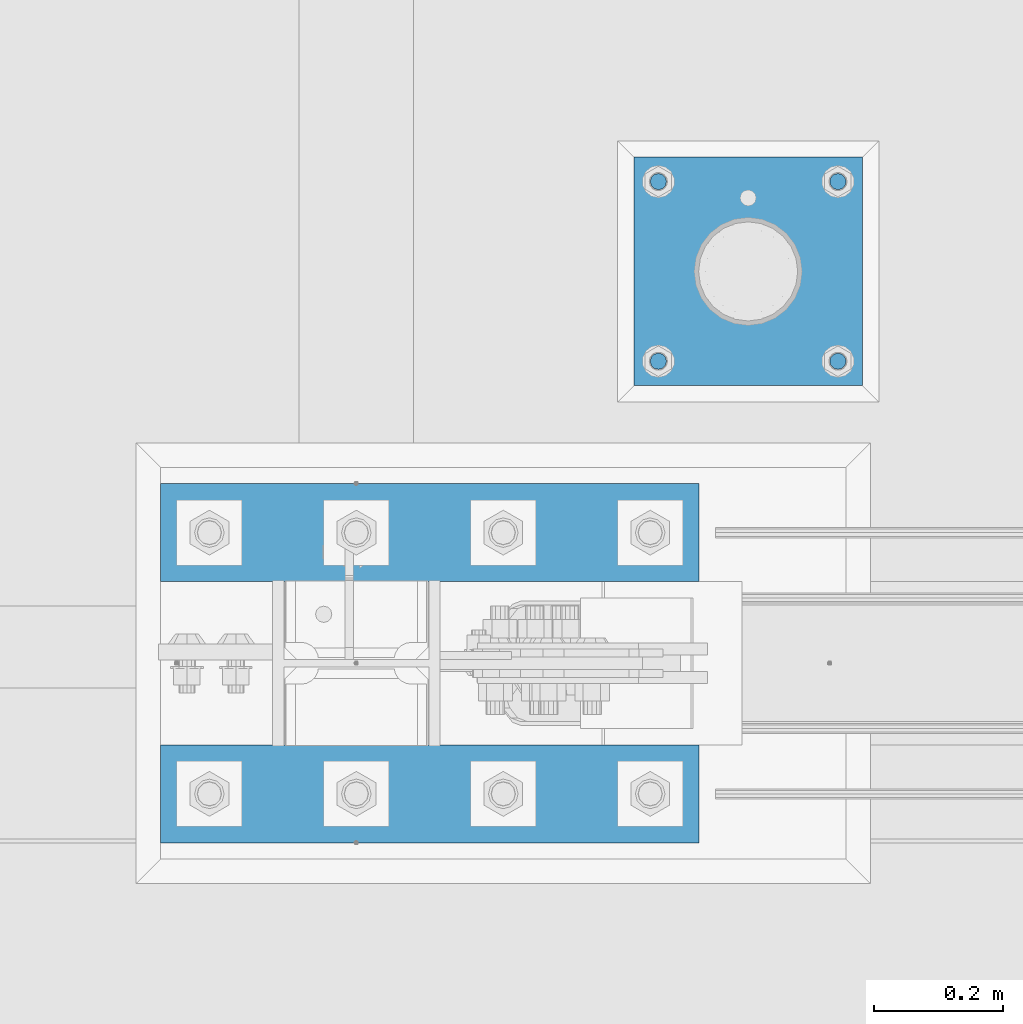
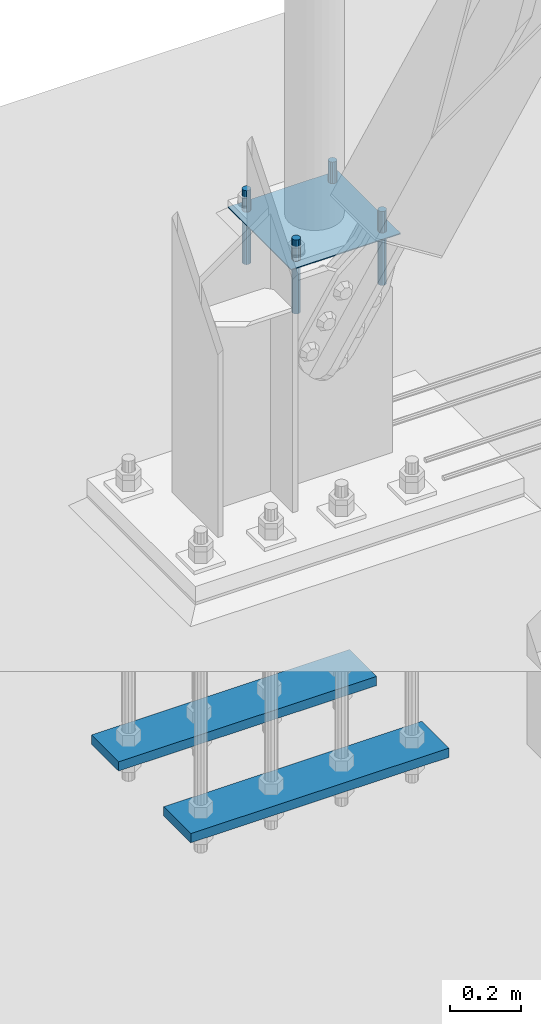
# One storey, part 2399 of 3843: 7 beams, 2 elements without a shape of their own.
"""IFC2X3 building model written with IfcOpenShell, lengths in millimetres."""

from ifc_helpers import new_model, si_unit, frame, origin_with_axes, place, context, subcontext, project, spatial, faceted_brep, material, type_object, element, aggregate, save


model = new_model("IFC2X3")

# Units and contexts
model_context = context("Model", 3, precision=1e-05, world=origin_with_axes())
body_context = subcontext(model_context, "Body", "Model", "MODEL_VIEW")
ifc_project = project(units=[si_unit("LENGTHUNIT", "METRE", prefix="MILLI"), si_unit("AREAUNIT", "SQUARE_METRE"), si_unit("VOLUMEUNIT", "CUBIC_METRE"), si_unit("MASSUNIT", "GRAM", prefix="KILO"), si_unit("TIMEUNIT", "SECOND"), si_unit("PLANEANGLEUNIT", "RADIAN"), si_unit("SOLIDANGLEUNIT", "STERADIAN"), si_unit("THERMODYNAMICTEMPERATUREUNIT", "DEGREE_CELSIUS"), si_unit("LUMINOUSINTENSITYUNIT", "LUMEN")], contexts=[model_context])

# Site, building, storey
site_placement = place(None, origin_with_axes())
site = spatial("IfcSite", under=ifc_project, at=site_placement, CompositionType="ELEMENT")
building_placement = place(site_placement, origin_with_axes())
building = spatial("IfcBuilding", under=site, at=building_placement, Name="Undefined", CompositionType="ELEMENT")
storey_placement = place(building_placement, origin_with_axes())
storey = spatial("IfcBuildingStorey", under=building, at=storey_placement, Name="Undefined", CompositionType="ELEMENT", Elevation=0.0)

# Assembly, beams
assembly_1_placement = place(storey_placement, origin_with_axes())
assembly_1 = element("IfcElementAssembly", 1, at=assembly_1_placement, inside=storey, Name="TEMPLATE", AssemblyPlace="NOTDEFINED", PredefinedType="RIGID_FRAME")
ifc_material_1 = material(Name="STEEL/316 SS")
beam_type_1 = type_object("IfcBeamType", PredefinedType="NOTDEFINED")
beam_1_placement = place(assembly_1_placement, frame((23609.3, 89585.8, 30581.6), z_axis=(1.0, 0.0, 0.0), x_axis=(0.0, 0.0, -1.0)))
beam_1 = element("IfcBeam", 2, at=beam_1_placement, type_object=beam_type_1, material=ifc_material_1, Name="ANCHOR_ROD", context=body_context, shape_type="Brep", body=[
    faceted_brep([(0.0, -12.6999999999971, 0.0), (0.0, -10.9985226280696, -6.34999999999854), (253.999, -10.9985226280696, -6.34999999999854), (253.999, -12.6999999999971, 0.0), (0.0, -6.35000000000582, -10.9985226280623), (253.999, -6.35000000000582, -10.9985226280623), (0.0, 0.0, -12.6999999999971), (253.999, 0.0, -12.6999999999971), (0.0, 6.35000000000582, -10.9985226280623), (253.999, 6.35000000000582, -10.9985226280623), (0.0, 10.9985226280696, -6.34999999999854), (253.999, 10.9985226280696, -6.34999999999854), (0.0, 12.6999999999971, 0.0), (253.999, 12.6999999999971, 0.0), (0.0, 10.9985226280696, 6.34999999999854), (253.999, 10.9985226280696, 6.34999999999854), (0.0, 6.35000000000582, 10.9985226280623), (253.999, 6.35000000000582, 10.9985226280623), (0.0, 0.0, 12.6999999999971), (253.999, 0.0, 12.6999999999971), (0.0, -6.35000000000582, 10.9985226280623), (253.999, -6.35000000000582, 10.9985226280623), (0.0, -10.9985226280696, 6.34999999999854), (253.999, -10.9985226280696, 6.34999999999854)], [[[0, 1, 2, 3]], [[1, 4, 5, 2]], [[4, 6, 7, 5]], [[6, 8, 9, 7]], [[8, 10, 11, 9]], [[10, 12, 13, 11]], [[12, 14, 15, 13]], [[14, 16, 17, 15]], [[16, 18, 19, 17]], [[18, 20, 21, 19]], [[20, 22, 23, 21]], [[22, 0, 3, 23]], [[5, 7, 9, 11, 13, 15, 17, 19, 21, 23, 3, 2]], [[22, 20, 18, 16, 14, 12, 10, 8, 6, 4, 1, 0]]]),
])
beam_2_placement = place(assembly_1_placement, frame((23609.3, 89865.2, 30581.6), z_axis=(-1.0, 0.0, 0.0), x_axis=(0.0, 0.0, -1.0)))
beam_2 = element("IfcBeam", 3, at=beam_2_placement, type_object=beam_type_1, material=ifc_material_1, Name="ANCHOR_ROD", context=body_context, shape_type="Brep", body=[
    faceted_brep([(0.0, -12.6999999999971, 0.0), (0.0, -10.9985226280696, -6.34999999999854), (253.999, -10.9985226280696, -6.34999999999854), (253.999, -12.6999999999971, 0.0), (0.0, -6.35000000000582, -10.9985226280623), (253.999, -6.35000000000582, -10.9985226280623), (0.0, 0.0, -12.6999999999971), (253.999, 0.0, -12.6999999999971), (0.0, 6.35000000000582, -10.9985226280623), (253.999, 6.35000000000582, -10.9985226280623), (0.0, 10.9985226280696, -6.34999999999854), (253.999, 10.9985226280696, -6.34999999999854), (0.0, 12.6999999999971, 0.0), (253.999, 12.6999999999971, 0.0), (0.0, 10.9985226280696, 6.34999999999854), (253.999, 10.9985226280696, 6.34999999999854), (0.0, 6.35000000000582, 10.9985226280623), (253.999, 6.35000000000582, 10.9985226280623), (0.0, 0.0, 12.6999999999971), (253.999, 0.0, 12.6999999999971), (0.0, -6.35000000000582, 10.9985226280623), (253.999, -6.35000000000582, 10.9985226280623), (0.0, -10.9985226280696, 6.34999999999854), (253.999, -10.9985226280696, 6.34999999999854)], [[[0, 1, 2, 3]], [[1, 4, 5, 2]], [[4, 6, 7, 5]], [[6, 8, 9, 7]], [[8, 10, 11, 9]], [[10, 12, 13, 11]], [[12, 14, 15, 13]], [[14, 16, 17, 15]], [[16, 18, 19, 17]], [[18, 20, 21, 19]], [[20, 22, 23, 21]], [[22, 0, 3, 23]], [[5, 7, 9, 11, 13, 15, 17, 19, 21, 23, 3, 2]], [[22, 20, 18, 16, 14, 12, 10, 8, 6, 4, 1, 0]]]),
])
beam_3_placement = place(assembly_1_placement, frame((23329.9, 89585.8, 30581.6), z_axis=(1.0, 0.0, 0.0), x_axis=(0.0, 0.0, -1.0)))
beam_3 = element("IfcBeam", 4, at=beam_3_placement, type_object=beam_type_1, material=ifc_material_1, Name="ANCHOR_ROD", context=body_context, shape_type="Brep", body=[
    faceted_brep([(0.0, -12.6999999999971, 0.0), (0.0, -10.9985226280696, -6.34999999999854), (253.999, -10.9985226280696, -6.34999999999854), (253.999, -12.6999999999971, 0.0), (0.0, -6.35000000000582, -10.9985226280623), (253.999, -6.35000000000582, -10.9985226280623), (0.0, 0.0, -12.6999999999971), (253.999, 0.0, -12.6999999999971), (0.0, 6.35000000000582, -10.9985226280623), (253.999, 6.35000000000582, -10.9985226280623), (0.0, 10.9985226280696, -6.34999999999854), (253.999, 10.9985226280696, -6.34999999999854), (0.0, 12.6999999999971, 0.0), (253.999, 12.6999999999971, 0.0), (0.0, 10.9985226280696, 6.34999999999854), (253.999, 10.9985226280696, 6.34999999999854), (0.0, 6.35000000000582, 10.9985226280623), (253.999, 6.35000000000582, 10.9985226280623), (0.0, 0.0, 12.6999999999971), (253.999, 0.0, 12.6999999999971), (0.0, -6.35000000000582, 10.9985226280623), (253.999, -6.35000000000582, 10.9985226280623), (0.0, -10.9985226280696, 6.34999999999854), (253.999, -10.9985226280696, 6.34999999999854)], [[[0, 1, 2, 3]], [[1, 4, 5, 2]], [[4, 6, 7, 5]], [[6, 8, 9, 7]], [[8, 10, 11, 9]], [[10, 12, 13, 11]], [[12, 14, 15, 13]], [[14, 16, 17, 15]], [[16, 18, 19, 17]], [[18, 20, 21, 19]], [[20, 22, 23, 21]], [[22, 0, 3, 23]], [[5, 7, 9, 11, 13, 15, 17, 19, 21, 23, 3, 2]], [[22, 20, 18, 16, 14, 12, 10, 8, 6, 4, 1, 0]]]),
])
beam_4_placement = place(assembly_1_placement, frame((23329.9, 89865.2, 30581.6), z_axis=(-1.0, 0.0, 0.0), x_axis=(0.0, 0.0, -1.0)))
beam_4 = element("IfcBeam", 5, at=beam_4_placement, type_object=beam_type_1, material=ifc_material_1, Name="ANCHOR_ROD", context=body_context, shape_type="Brep", body=[
    faceted_brep([(0.0, -12.6999999999971, 0.0), (0.0, -10.9985226280696, -6.34999999999854), (253.999, -10.9985226280696, -6.34999999999854), (253.999, -12.6999999999971, 0.0), (0.0, -6.35000000000582, -10.9985226280623), (253.999, -6.35000000000582, -10.9985226280623), (0.0, 0.0, -12.6999999999971), (253.999, 0.0, -12.6999999999971), (0.0, 6.35000000000582, -10.9985226280623), (253.999, 6.35000000000582, -10.9985226280623), (0.0, 10.9985226280696, -6.34999999999854), (253.999, 10.9985226280696, -6.34999999999854), (0.0, 12.6999999999971, 0.0), (253.999, 12.6999999999971, 0.0), (0.0, 10.9985226280696, 6.34999999999854), (253.999, 10.9985226280696, 6.34999999999854), (0.0, 6.35000000000582, 10.9985226280623), (253.999, 6.35000000000582, 10.9985226280623), (0.0, 0.0, 12.6999999999971), (253.999, 0.0, 12.6999999999971), (0.0, -6.35000000000582, 10.9985226280623), (253.999, -6.35000000000582, 10.9985226280623), (0.0, -10.9985226280696, 6.34999999999854), (253.999, -10.9985226280696, 6.34999999999854)], [[[0, 1, 2, 3]], [[1, 4, 5, 2]], [[4, 6, 7, 5]], [[6, 8, 9, 7]], [[8, 10, 11, 9]], [[10, 12, 13, 11]], [[12, 14, 15, 13]], [[14, 16, 17, 15]], [[16, 18, 19, 17]], [[18, 20, 21, 19]], [[20, 22, 23, 21]], [[22, 0, 3, 23]], [[5, 7, 9, 11, 13, 15, 17, 19, 21, 23, 3, 2]], [[22, 20, 18, 16, 14, 12, 10, 8, 6, 4, 1, 0]]]),
])
ifc_material_2 = material(Name="STEEL/A36")
beam_type_2 = type_object("IfcBeamType", PredefinedType="NOTDEFINED")
beam_5_placement = place(assembly_1_placement, frame((23647.4, 89725.5, 30506.9875), z_axis=(0.0, -1.0, 0.0), x_axis=(-1.0, 0.0, 0.0)))
beam_5 = element("IfcBeam", 6, at=beam_5_placement, type_object=beam_type_2, material=ifc_material_2, Name="TEMPLATE", context=body_context, shape_type="Brep", body=[
    faceted_brep([(0.0, 1.58750000000146, -177.800000000003), (0.0, 1.58750000000146, 177.800000000003), (355.600000000006, 1.58750000000146, 177.800000000003), (355.600000000006, 1.58750000000146, -177.800000000003), (0.0, -1.58750000000146, 177.800000000003), (355.600000000006, -1.58750000000146, 177.800000000003), (0.0, -1.58750000000146, -177.800000000003), (355.600000000006, -1.58750000000146, -177.800000000003)], [[[0, 1, 2, 3]], [[1, 4, 5, 2]], [[4, 6, 7, 5]], [[6, 0, 3, 7]], [[5, 7, 3, 2]], [[6, 4, 1, 0]]]),
])
aggregate(assembly_1, [beam_1, beam_2, beam_3, beam_4, beam_5])

assembly_2_placement = place(storey_placement, origin_with_axes())
assembly_2 = element("IfcElementAssembly", 7, at=assembly_2_placement, inside=storey, Name="TEMPLATE", AssemblyPlace="NOTDEFINED", PredefinedType="RIGID_FRAME")
ifc_material_3 = material(Name="STEEL/A572-50")
beam_type_3 = type_object("IfcBeamType", PredefinedType="NOTDEFINED")
beam_6_placement = place(assembly_2_placement, frame((23393.4, 88912.7, 29244.925), z_axis=(0.0, 1.0, 0.0), x_axis=(-1.0, 0.0, 0.0)))
beam_6 = element("IfcBeam", 8, at=beam_6_placement, type_object=beam_type_3, material=ifc_material_3, context=body_context, shape_type="Brep", body=[
    faceted_brep([(0.0, 15.875, -76.1999999999971), (0.0, 15.875, 76.1999999999971), (838.199999999997, 15.875, 76.1999999999971), (838.199999999997, 15.875, -76.1999999999971), (0.0, -15.875, 76.1999999999971), (838.199999999997, -15.875, 76.1999999999971), (0.0, -15.875, -76.1999999999971), (838.199999999997, -15.875, -76.1999999999971)], [[[0, 1, 2, 3]], [[1, 4, 5, 2]], [[4, 6, 7, 5]], [[6, 0, 3, 7]], [[5, 7, 3, 2]], [[6, 4, 1, 0]]]),
])
beam_7_placement = place(assembly_2_placement, frame((23393.4, 89319.1, 29244.925), z_axis=(0.0, 1.0, 0.0), x_axis=(-1.0, 0.0, 0.0)))
beam_7 = element("IfcBeam", 9, at=beam_7_placement, type_object=beam_type_3, material=ifc_material_3, context=body_context, shape_type="Brep", body=[
    faceted_brep([(0.0, 15.875, -76.1999999999971), (0.0, 15.875, 76.1999999999971), (838.199999999997, 15.875, 76.1999999999971), (838.199999999997, 15.875, -76.1999999999971), (0.0, -15.875, 76.1999999999971), (838.199999999997, -15.875, 76.1999999999971), (0.0, -15.875, -76.1999999999971), (838.199999999997, -15.875, -76.1999999999971)], [[[0, 1, 2, 3]], [[1, 4, 5, 2]], [[4, 6, 7, 5]], [[6, 0, 3, 7]], [[5, 7, 3, 2]], [[6, 4, 1, 0]]]),
])
aggregate(assembly_2, [beam_6, beam_7])

save(model, "model.ifc")
